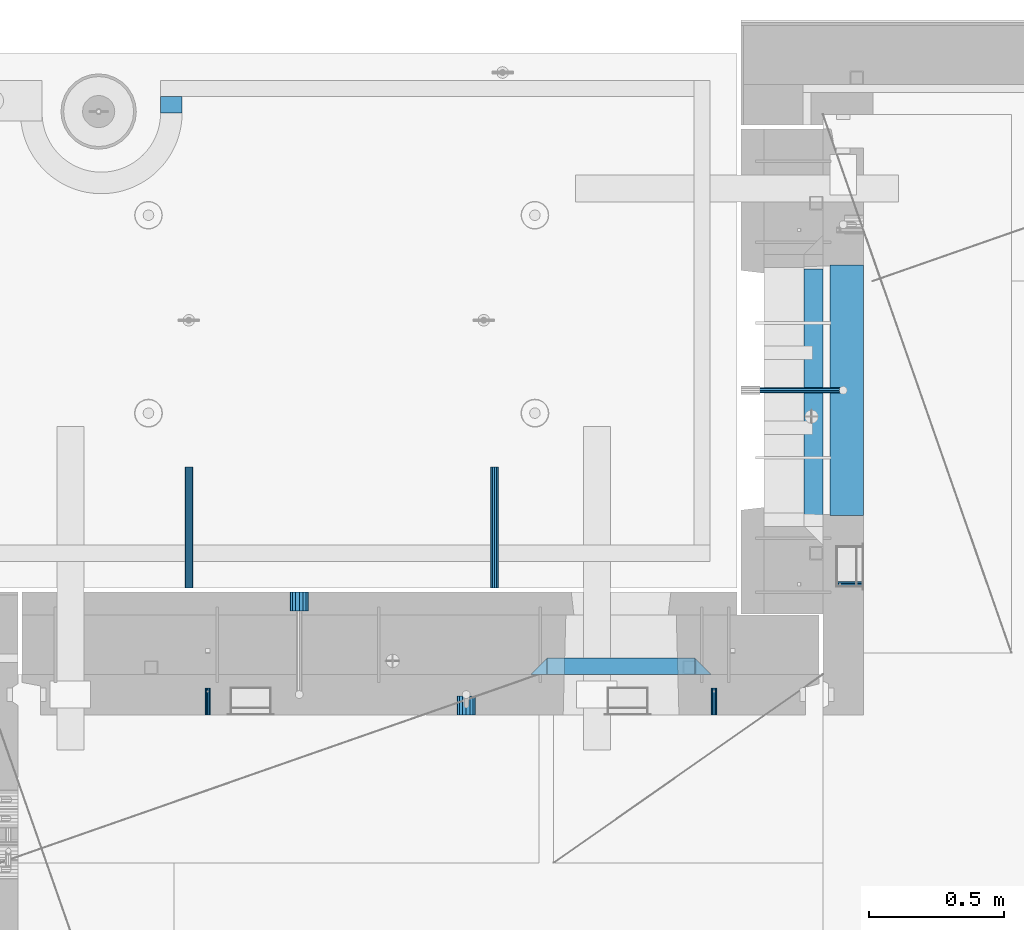
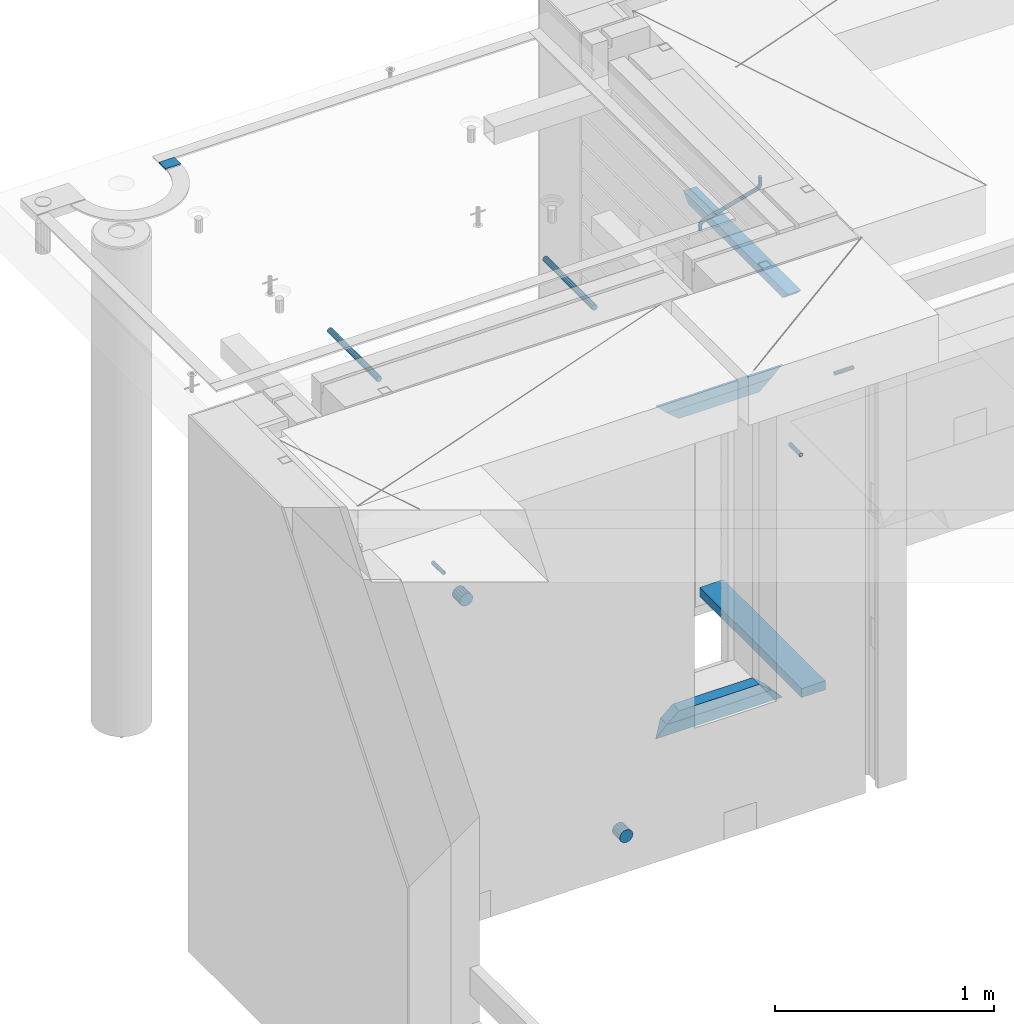
# One storey, part 157 of 350: 15 beams, 8 elements without a shape of their own.
"""IFC2X3 building model written with IfcOpenShell, lengths in millimetres."""

from ifc_helpers import new_model, si_unit, frame, origin_with_axes, place, context, subcontext, project, spatial, faceted_brep, material, type_object, element, aggregate, save


model = new_model("IFC2X3")

# Units and contexts
model_context = context("Model", 3, precision=1e-05, world=origin_with_axes())
body_context = subcontext(model_context, "Body", "Model", "MODEL_VIEW")
ifc_project = project(units=[si_unit("LENGTHUNIT", "METRE", prefix="MILLI"), si_unit("AREAUNIT", "SQUARE_METRE"), si_unit("VOLUMEUNIT", "CUBIC_METRE"), si_unit("MASSUNIT", "GRAM", prefix="KILO"), si_unit("TIMEUNIT", "SECOND"), si_unit("PLANEANGLEUNIT", "RADIAN"), si_unit("SOLIDANGLEUNIT", "STERADIAN"), si_unit("THERMODYNAMICTEMPERATUREUNIT", "DEGREE_CELSIUS"), si_unit("LUMINOUSINTENSITYUNIT", "LUMEN")], contexts=[model_context])

# Site, building, storey
site_placement = place(None, origin_with_axes())
site = spatial("IfcSite", under=ifc_project, at=site_placement, CompositionType="ELEMENT")
building_placement = place(site_placement, origin_with_axes())
building = spatial("IfcBuilding", under=site, at=building_placement, CompositionType="ELEMENT")
storey_placement = place(building_placement, origin_with_axes())
storey = spatial("IfcBuildingStorey", under=building, at=storey_placement, Name="2", CompositionType="ELEMENT", Elevation=0.0)

# Assembly, beam
assembly_1_placement = place(storey_placement, origin_with_axes())
assembly_1 = element("IfcElementAssembly", 1, at=assembly_1_placement, inside=storey, AssemblyPlace="NOTDEFINED", PredefinedType="REINFORCEMENT_UNIT")
ifc_material_1 = material(Name="CONCRETE/C25/30")
beam_type_1 = type_object("IfcBeamType", PredefinedType="NOTDEFINED")
beam_1_placement = place(assembly_1_placement, frame((10955.0, 22139.9998901814, 87080.0), z_axis=(0.0, 0.0, -1.0), x_axis=(0.0, -1.0, 0.0)))
beam_1 = element("IfcBeam", 2, at=beam_1_placement, type_object=beam_type_1, material=ifc_material_1, Name="SK", context=body_context, shape_type="Brep", body=[
    faceted_brep([(100.641025641038, 35.0, 20.6410256410309), (55.0, 35.0, -25.0), (55.0, -35.0, -25.0), (98.8461538461561, -35.0, 18.8461538461561), (966.153464684117, -35.0, 18.8461538461561), (964.358592889246, 35.0, 20.6410256410309), (1009.99961853027, 35.0, -25.0), (1009.99961853027, -35.0, -25.0)], [[[0, 1, 2, 3]], [[0, 3, 4, 5]], [[1, 0, 5, 6]], [[2, 1, 6, 7]], [[3, 2, 7, 4]], [[4, 7, 6, 5]]]),
])

# Assemblies, beams
assembly_2_placement = place(storey_placement, origin_with_axes())
assembly_2 = element("IfcElementAssembly", 3, at=assembly_2_placement, inside=storey, AssemblyPlace="NOTDEFINED", PredefinedType="REINFORCEMENT_UNIT")
assembly_3_placement = place(assembly_2_placement, origin_with_axes())
assembly_3 = element("IfcElementAssembly", 4, at=assembly_3_placement, Name="Steel Assembly", AssemblyPlace="NOTDEFINED", PredefinedType="RIGID_FRAME")
ifc_material_2 = material(Name="STEEL/Steel_Undefined")
beam_type_2 = type_object("IfcBeamType", PredefinedType="NOTDEFINED")
beam_2_placement = place(assembly_3_placement, frame((8704.99903261663, 20429.9951872276, 86755.0), z_axis=(1.0, 0.0, 0.0), x_axis=(0.0, 1.0, 0.0)))
beam_2 = element("IfcBeam", 5, at=beam_2_placement, type_object=beam_type_2, material=ifc_material_2, Name="M16", context=body_context, shape_type="Brep", body=[
    faceted_brep([(0.0, -8.49999999999272, -1.45519152283669e-11), (0.0, -7.36121593215648, 4.24999999998545), (100.000000000262, -7.36121593215648, 4.24999999998545), (100.000000000262, -8.49999999999272, -1.45519152283669e-11), (0.0, -4.24999999998545, 7.36121593216376), (100.000000000262, -4.24999999998545, 7.36121593216376), (0.0, 1.45519152283669e-11, 8.49999999998545), (100.000000000262, 1.45519152283669e-11, 8.49999999998545), (0.0, 4.25000000001455, 7.36121593216376), (100.000000000262, 4.25000000001455, 7.36121593216376), (0.0, 7.36121593217104, 4.24999999998545), (100.000000000262, 7.36121593217104, 4.24999999998545), (0.0, 8.50000000000728, 0.0), (100.000000000262, 8.50000000000728, 0.0), (0.0, 7.36121593217104, -4.25000000001455), (100.000000000262, 7.36121593217104, -4.25000000001455), (0.0, 4.25000000000728, -7.36121593219286), (100.000000000262, 4.25000000000728, -7.36121593219286), (0.0, 7.27595761418343e-12, -8.5), (100.000000000262, 7.27595761418343e-12, -8.5), (0.0, -4.24999999999272, -7.36121593217831), (100.000000000262, -4.24999999999272, -7.36121593217831), (0.0, -7.36121593215648, -4.25), (100.000000000262, -7.36121593215648, -4.25), (0.0, -10.4999999999927, -1.45519152283669e-11), (0.0, -9.09326673972828, -5.25000000001455), (100.000000000262, -9.09326673972828, -5.25000000001455), (100.000000000262, -10.4999999999927, -1.45519152283669e-11), (0.0, -5.24999999998545, -9.09326673974283), (100.000000000262, -5.24999999998545, -9.09326673974283), (0.0, 7.27595761418343e-12, -10.5), (100.000000000262, 7.27595761418343e-12, -10.5), (0.0, 5.25000000001455, -9.09326673975738), (100.000000000262, 5.25000000001455, -9.09326673975738), (0.0, 9.09326673975011, -5.25000000001455), (100.000000000262, 9.09326673975011, -5.25000000001455), (0.0, 10.5000000000073, -1.45519152283669e-11), (100.000000000262, 10.5000000000073, -1.45519152283669e-11), (0.0, 9.09326673975011, 5.25), (100.000000000262, 9.09326673975011, 5.25), (0.0, 5.25000000000728, 9.09326673972828), (100.000000000262, 5.25000000000728, 9.09326673972828), (0.0, 1.45519152283669e-11, 10.4999999999854), (100.000000000262, 1.45519152283669e-11, 10.4999999999854), (0.0, -5.24999999999272, 9.09326673972828), (100.000000000262, -5.24999999999272, 9.09326673972828), (0.0, -9.09326673972828, 5.24999999998545), (100.000000000262, -9.09326673972828, 5.24999999998545)], [[[0, 1, 2, 3]], [[1, 4, 5, 2]], [[4, 6, 7, 5]], [[6, 8, 9, 7]], [[8, 10, 11, 9]], [[10, 12, 13, 11]], [[12, 14, 15, 13]], [[14, 16, 17, 15]], [[16, 18, 19, 17]], [[18, 20, 21, 19]], [[20, 22, 23, 21]], [[22, 0, 3, 23]], [[24, 25, 26, 27]], [[25, 28, 29, 26]], [[28, 30, 31, 29]], [[30, 32, 33, 31]], [[32, 34, 35, 33]], [[34, 36, 37, 35]], [[36, 38, 39, 37]], [[38, 40, 41, 39]], [[40, 42, 43, 41]], [[42, 44, 45, 43]], [[44, 46, 47, 45]], [[46, 24, 27, 47]], [[29, 31, 33, 35, 37, 39, 41, 43, 45, 47, 27, 26], [5, 7, 9, 11, 13, 15, 17, 19, 21, 23, 3, 2]], [[46, 44, 42, 40, 38, 36, 34, 32, 30, 28, 25, 24], [22, 20, 18, 16, 14, 12, 10, 8, 6, 4, 1, 0]]]),
])
aggregate(assembly_3, [beam_2])
assembly_4_placement = place(assembly_2_placement, origin_with_axes())
assembly_4 = element("IfcElementAssembly", 6, at=assembly_4_placement, Name="Steel Assembly", AssemblyPlace="NOTDEFINED", PredefinedType="RIGID_FRAME")
beam_3_placement = place(assembly_4_placement, frame((10584.9990326166, 20429.9951872276, 86755.0), z_axis=(1.0, 0.0, 0.0), x_axis=(0.0, 1.0, 0.0)))
beam_3 = element("IfcBeam", 7, at=beam_3_placement, type_object=beam_type_2, material=ifc_material_2, Name="M16", context=body_context, shape_type="Brep", body=[
    faceted_brep([(0.0, -8.49999999999272, -1.45519152283669e-11), (0.0, -7.36121593215648, 4.24999999998545), (100.000000000262, -7.36121593215648, 4.24999999998545), (100.000000000262, -8.49999999999272, -1.45519152283669e-11), (0.0, -4.24999999998545, 7.36121593216376), (100.000000000262, -4.24999999998545, 7.36121593216376), (0.0, 1.45519152283669e-11, 8.49999999998545), (100.000000000262, 1.45519152283669e-11, 8.49999999998545), (0.0, 4.25000000001455, 7.36121593216376), (100.000000000262, 4.25000000001455, 7.36121593216376), (0.0, 7.36121593217104, 4.24999999998545), (100.000000000262, 7.36121593217104, 4.24999999998545), (0.0, 8.50000000000728, 0.0), (100.000000000262, 8.50000000000728, 0.0), (0.0, 7.36121593217104, -4.25000000001455), (100.000000000262, 7.36121593217104, -4.25000000001455), (0.0, 4.25000000000728, -7.36121593219286), (100.000000000262, 4.25000000000728, -7.36121593219286), (0.0, 7.27595761418343e-12, -8.5), (100.000000000262, 7.27595761418343e-12, -8.5), (0.0, -4.24999999999272, -7.36121593217831), (100.000000000262, -4.24999999999272, -7.36121593217831), (0.0, -7.36121593215648, -4.25), (100.000000000262, -7.36121593215648, -4.25), (0.0, -10.4999999999927, -1.45519152283669e-11), (0.0, -9.09326673972828, -5.25000000001455), (100.000000000262, -9.09326673972828, -5.25000000001455), (100.000000000262, -10.4999999999927, -1.45519152283669e-11), (0.0, -5.24999999998545, -9.09326673974283), (100.000000000262, -5.24999999998545, -9.09326673974283), (0.0, 7.27595761418343e-12, -10.5), (100.000000000262, 7.27595761418343e-12, -10.5), (0.0, 5.25000000001455, -9.09326673975738), (100.000000000262, 5.25000000001455, -9.09326673975738), (0.0, 9.09326673975011, -5.25000000001455), (100.000000000262, 9.09326673975011, -5.25000000001455), (0.0, 10.5000000000073, -1.45519152283669e-11), (100.000000000262, 10.5000000000073, -1.45519152283669e-11), (0.0, 9.09326673975011, 5.25), (100.000000000262, 9.09326673975011, 5.25), (0.0, 5.25000000000728, 9.09326673972828), (100.000000000262, 5.25000000000728, 9.09326673972828), (0.0, 1.45519152283669e-11, 10.4999999999854), (100.000000000262, 1.45519152283669e-11, 10.4999999999854), (0.0, -5.24999999999272, 9.09326673972828), (100.000000000262, -5.24999999999272, 9.09326673972828), (0.0, -9.09326673972828, 5.24999999998545), (100.000000000262, -9.09326673972828, 5.24999999998545)], [[[0, 1, 2, 3]], [[1, 4, 5, 2]], [[4, 6, 7, 5]], [[6, 8, 9, 7]], [[8, 10, 11, 9]], [[10, 12, 13, 11]], [[12, 14, 15, 13]], [[14, 16, 17, 15]], [[16, 18, 19, 17]], [[18, 20, 21, 19]], [[20, 22, 23, 21]], [[22, 0, 3, 23]], [[24, 25, 26, 27]], [[25, 28, 29, 26]], [[28, 30, 31, 29]], [[30, 32, 33, 31]], [[32, 34, 35, 33]], [[34, 36, 37, 35]], [[36, 38, 39, 37]], [[38, 40, 41, 39]], [[40, 42, 43, 41]], [[42, 44, 45, 43]], [[44, 46, 47, 45]], [[46, 24, 27, 47]], [[29, 31, 33, 35, 37, 39, 41, 43, 45, 47, 27, 26], [5, 7, 9, 11, 13, 15, 17, 19, 21, 23, 3, 2]], [[46, 44, 42, 40, 38, 36, 34, 32, 30, 28, 25, 24], [22, 20, 18, 16, 14, 12, 10, 8, 6, 4, 1, 0]]]),
])
aggregate(assembly_4, [beam_3])

# Assembly, beam
assembly_5_placement = place(assembly_1_placement, origin_with_axes())
assembly_5 = element("IfcElementAssembly", 8, at=assembly_5_placement, Name="Steel Assembly", AssemblyPlace="NOTDEFINED", PredefinedType="RIGID_FRAME")
beam_4_placement = place(assembly_5_placement, frame((11140.0, 20914.9954408996, 86755.0), z_axis=(0.0, -1.0, 0.0), x_axis=(-1.0, 3.00000001838171e-08, 0.0)))
beam_4 = element("IfcBeam", 9, at=beam_4_placement, type_object=beam_type_2, material=ifc_material_2, Name="M16", context=body_context, shape_type="Brep", body=[
    faceted_brep([(0.0, -8.49999999999272, -1.45519152283669e-11), (0.0, -7.36121593215648, 4.24999999998545), (100.000000000262, -7.36121593215648, 4.24999999998545), (100.000000000262, -8.49999999999272, -1.45519152283669e-11), (0.0, -4.24999999998545, 7.36121593216376), (100.000000000262, -4.24999999998545, 7.36121593216376), (0.0, 1.45519152283669e-11, 8.49999999998545), (100.000000000262, 1.45519152283669e-11, 8.49999999998545), (0.0, 4.25000000001455, 7.36121593216376), (100.000000000262, 4.25000000001455, 7.36121593216376), (0.0, 7.36121593217104, 4.24999999998545), (100.000000000262, 7.36121593217104, 4.24999999998545), (0.0, 8.50000000000728, 0.0), (100.000000000262, 8.50000000000728, 0.0), (0.0, 7.36121593217104, -4.25000000001455), (100.000000000262, 7.36121593217104, -4.25000000001455), (0.0, 4.25000000000728, -7.36121593219286), (100.000000000262, 4.25000000000728, -7.36121593219286), (0.0, 7.27595761418343e-12, -8.5), (100.000000000262, 7.27595761418343e-12, -8.5), (0.0, -4.24999999999272, -7.36121593217831), (100.000000000262, -4.24999999999272, -7.36121593217831), (0.0, -7.36121593215648, -4.25), (100.000000000262, -7.36121593215648, -4.25), (0.0, -10.4999999999927, -1.45519152283669e-11), (0.0, -9.09326673972828, -5.25000000001455), (100.000000000262, -9.09326673972828, -5.25000000001455), (100.000000000262, -10.4999999999927, -1.45519152283669e-11), (0.0, -5.24999999998545, -9.09326673974283), (100.000000000262, -5.24999999998545, -9.09326673974283), (0.0, 7.27595761418343e-12, -10.5), (100.000000000262, 7.27595761418343e-12, -10.5), (0.0, 5.25000000001455, -9.09326673975738), (100.000000000262, 5.25000000001455, -9.09326673975738), (0.0, 9.09326673975011, -5.25000000001455), (100.000000000262, 9.09326673975011, -5.25000000001455), (0.0, 10.5000000000073, -1.45519152283669e-11), (100.000000000262, 10.5000000000073, -1.45519152283669e-11), (0.0, 9.09326673975011, 5.25), (100.000000000262, 9.09326673975011, 5.25), (0.0, 5.25000000000728, 9.09326673972828), (100.000000000262, 5.25000000000728, 9.09326673972828), (0.0, 1.45519152283669e-11, 10.4999999999854), (100.000000000262, 1.45519152283669e-11, 10.4999999999854), (0.0, -5.24999999999272, 9.09326673972828), (100.000000000262, -5.24999999999272, 9.09326673972828), (0.0, -9.09326673972828, 5.24999999998545), (100.000000000262, -9.09326673972828, 5.24999999998545)], [[[0, 1, 2, 3]], [[1, 4, 5, 2]], [[4, 6, 7, 5]], [[6, 8, 9, 7]], [[8, 10, 11, 9]], [[10, 12, 13, 11]], [[12, 14, 15, 13]], [[14, 16, 17, 15]], [[16, 18, 19, 17]], [[18, 20, 21, 19]], [[20, 22, 23, 21]], [[22, 0, 3, 23]], [[24, 25, 26, 27]], [[25, 28, 29, 26]], [[28, 30, 31, 29]], [[30, 32, 33, 31]], [[32, 34, 35, 33]], [[34, 36, 37, 35]], [[36, 38, 39, 37]], [[38, 40, 41, 39]], [[40, 42, 43, 41]], [[42, 44, 45, 43]], [[44, 46, 47, 45]], [[46, 24, 27, 47]], [[29, 31, 33, 35, 37, 39, 41, 43, 45, 47, 27, 26], [5, 7, 9, 11, 13, 15, 17, 19, 21, 23, 3, 2]], [[46, 44, 42, 40, 38, 36, 34, 32, 30, 28, 25, 24], [22, 20, 18, 16, 14, 12, 10, 8, 6, 4, 1, 0]]]),
])
aggregate(assembly_5, [beam_4])

# Beam
ifc_material_3 = material()
beam_type_3 = type_object("IfcBeamType", Name="D20", PredefinedType="NOTDEFINED")
beam_5_placement = place(assembly_1_placement, frame((10747.93, 21634.9982799665, 87220.28), z_axis=(0.999209485784166, 0.00020572799995638, -0.0397537569914116), x_axis=(0.0397537569984931, -6.39999925638531e-08, 0.999209506962629)))
beam_5 = element("IfcBeam", 10, at=beam_5_placement, type_object=beam_type_3, material=ifc_material_3, Name="JM20", ObjectType="D20", context=body_context, shape_type="Brep", body=[
    faceted_brep([(0.0, -10.0, 0.0), (-4.19531716033816e-08, -7.07106781186667, -7.07106781187031), (26.3851730625611, -7.07106780271351, -7.07106779974674), (26.3851730660535, -9.99999999077045, 1.18243406177498e-08), (0.0, 0.0, -10.0), (26.3851730589668, 9.14587872102857e-09, -9.99999998788189), (4.196772351861e-08, 7.07106781186303, -7.07106781186667), (26.3851730576571, 7.07106782101255, -7.0710677997472), (0.0, 10.0, 0.0), (26.3851730593888, 10.0000000091495, 1.21176526590716e-08), (4.196772351861e-08, 7.07106781185939, 7.07106781185939), (26.3851730631723, 7.07106782101619, 7.07106782398387), (0.0, 0.0, 10.0), (26.3851730667375, 9.15315467864275e-09, 10.0000000121181), (-4.19531716033816e-08, -7.07106781187031, 7.07106781185939), (26.3851730680617, -7.07106780271351, 7.07106782398296), (38.6387990555377, 0.00053833780111745, -7.38336449283906), (37.4430586178205, -7.07058200552274, -4.70977034770021), (34.5550974405633, -9.99964106806146, 1.74460312923975), (31.6666440137633, -7.07083577596131, 8.19887149183023), (30.4697151806322, 0.000179452214069897, 10.8722118684241), (31.6654556183639, 7.07129979554884, 8.19861772327886), (34.5534167956066, 10.0003588580803, 1.74424424634026), (37.4418702223775, 7.07155356597286, -4.71002411625204), (46.5698109210789, 7.07292605872499, 1.96124086770624), (48.7548734831362, 0.00205940803425619, 0.0100898832683924), (41.2967727296491, 10.0013728005906, 6.67270684289633), (36.0246331664675, 7.07195524891722, 11.3845749391899), (33.8417400848848, 0.000686475628754124, 13.3366967298962), (36.0268026468402, -7.07018017507653, 11.385545745416), (41.2998408382991, -9.99862691692761, 6.67407977023777), (46.5719804015243, -7.06920936526149, 1.96221167398289), (52.1766955363273, 7.07494587836845, 11.77897587077), (54.9687243336812, 0.00429788071051007, 10.8906314292522), (45.4389138642146, 10.0028649622, 13.9256551011317), (38.7022804405424, 7.07291984242329, 16.0731735411446), (35.9130237601494, 0.00143263318750542, 16.9635440140905), (38.7050525575032, -7.06921536447044, 16.0751995724927), (45.4428342298197, -9.99713444846202, 13.9285203429881), (52.1794676532882, -7.06718932852891, 11.7810019021831), (142.166420299589, -7.00909836739083, 294.143799597011), (135.429786872017, -9.93904348683645, 296.291318034092), (144.955676979953, 0.0623888418631395, 293.253429124143), (142.163648182657, 7.13303683951744, 294.141773565681), (135.425866510661, 10.0609559233271, 296.288452795829), (128.689233087061, 7.13101080351771, 298.435971235634), (125.899976406712, 0.0595235942673753, 299.326341708503), (128.692005203993, -7.01112440339057, 298.437997266966), (147.068569920637, 0.0631443010061048, 296.926548661886), (144.897857494318, -7.00812174957537, 298.892215917644), (139.655137467547, -9.93753272500544, 303.636800386314), (134.411524128242, -7.00907940566321, 308.380988833921), (132.238655054738, 0.0617899707685865, 310.345700010335), (134.409367481101, 7.13305602133914, 308.38003275464), (139.652087507944, 10.0624669967765, 303.63544828606), (144.895700847192, 7.13401367743427, 298.891259838389), (149.349355837621, 7.13466950711154, 302.082919188319), (150.512901837996, 0.0636515012993186, 299.394888529177), (146.541460642286, 10.0634815017911, 308.572636332), (143.734043175544, 7.13442914049301, 315.062451673432), (142.571650514263, 0.0633115715718304, 317.750719402909), (143.735196514695, -7.0077064342513, 315.062688743805), (146.543091710148, -9.93651842893087, 308.572971600169), (149.350509176773, -7.0074660676255, 302.083156258706), (154.724909358454, 7.13488656737172, 303.143653317829), (154.670204234542, 0.063819369621342, 300.215230568659), (154.856921558763, 10.0638172729959, 310.213489346082), (154.988909878753, 7.13488360238989, 317.283324591871), (155.043557350815, 0.0638151764978829, 320.211745451903), (154.988852227005, -7.00725202125614, 317.28332270274), (154.856840031658, -9.93618272723688, 310.213486674455), (154.724851706691, -7.00724905626703, 303.143651428684), (199.544700311235, -7.00743165723543, 302.30682413155), (199.676688632229, -9.93636532781238, 309.37665937721), (199.490052838737, 0.0636367686238373, 299.378403271518), (199.544757962984, 7.13470396637786, 302.306826020583), (199.676770164122, 10.0636346720203, 309.376662048705), (199.808758485131, 7.13470100144696, 316.446497294365), (199.863405957614, 0.0636325755804137, 319.374918154397), (199.808700833368, -7.00743462216269, 316.446495405334)], [[[0, 1, 2, 3]], [[1, 4, 5, 2]], [[4, 6, 7, 5]], [[6, 8, 9, 7]], [[8, 10, 11, 9]], [[10, 12, 13, 11]], [[12, 14, 15, 13]], [[14, 0, 3, 15]], [[14, 12, 10, 8, 6, 4, 1, 0]], [[2, 5, 16, 17]], [[3, 2, 17, 18]], [[15, 3, 18, 19]], [[13, 15, 19, 20]], [[11, 13, 20, 21]], [[9, 11, 21, 22]], [[7, 9, 22, 23]], [[5, 7, 23, 16]], [[23, 24, 25, 16]], [[22, 26, 24, 23]], [[21, 27, 26, 22]], [[20, 28, 27, 21]], [[19, 29, 28, 20]], [[18, 30, 29, 19]], [[17, 31, 30, 18]], [[16, 25, 31, 17]], [[24, 32, 33, 25]], [[26, 34, 32, 24]], [[27, 35, 34, 26]], [[28, 36, 35, 27]], [[29, 37, 36, 28]], [[30, 38, 37, 29]], [[31, 39, 38, 30]], [[25, 33, 39, 31]], [[38, 39, 40, 41]], [[39, 33, 42, 40]], [[33, 32, 43, 42]], [[32, 34, 44, 43]], [[34, 35, 45, 44]], [[35, 36, 46, 45]], [[36, 37, 47, 46]], [[37, 38, 41, 47]], [[40, 42, 48, 49]], [[41, 40, 49, 50]], [[47, 41, 50, 51]], [[46, 47, 51, 52]], [[45, 46, 52, 53]], [[44, 45, 53, 54]], [[43, 44, 54, 55]], [[42, 43, 55, 48]], [[55, 56, 57, 48]], [[54, 58, 56, 55]], [[53, 59, 58, 54]], [[52, 60, 59, 53]], [[51, 61, 60, 52]], [[50, 62, 61, 51]], [[49, 63, 62, 50]], [[48, 57, 63, 49]], [[56, 64, 65, 57]], [[58, 66, 64, 56]], [[59, 67, 66, 58]], [[60, 68, 67, 59]], [[61, 69, 68, 60]], [[62, 70, 69, 61]], [[63, 71, 70, 62]], [[57, 65, 71, 63]], [[70, 71, 72, 73]], [[71, 65, 74, 72]], [[65, 64, 75, 74]], [[64, 66, 76, 75]], [[66, 67, 77, 76]], [[67, 68, 78, 77]], [[68, 69, 79, 78]], [[69, 70, 73, 79]], [[74, 75, 76, 77, 78, 79, 73, 72]]]),
])

beam_type_4 = type_object("IfcBeamType", Name="D70", PredefinedType="NOTDEFINED")
beam_6_placement = place(assembly_2_placement, frame((9665.00172002957, 20429.9951872276, 84955.0), z_axis=(0.0, 0.0, 1.0), x_axis=(0.0, 1.0, 0.0)))
beam_6 = element("IfcBeam", 11, at=beam_6_placement, type_object=beam_type_4, material=ifc_material_3, ObjectType="D70", context=body_context, shape_type="Brep", body=[
    faceted_brep([(0.0, -35.0, 0.0), (0.0, -32.3357836378964, -13.3939201327739), (70.0, -32.3357836378964, -13.3939201327739), (70.0, -35.0, 0.0), (0.0, -24.7487373415279, -24.7487373415352), (70.0, -24.7487373415279, -24.7487373415352), (0.0, -13.3939201327776, -32.3357836379), (70.0, -13.3939201327776, -32.3357836379), (0.0, 0.0, -35.0), (70.0, 0.0, -35.0), (0.0, 13.3939201327776, -32.3357836379), (70.0, 13.3939201327776, -32.3357836379), (0.0, 24.7487373415279, -24.7487373415352), (70.0, 24.7487373415279, -24.7487373415352), (0.0, 32.3357836378964, -13.3939201327739), (70.0, 32.3357836378964, -13.3939201327739), (0.0, 35.0, 0.0), (70.0, 35.0, 0.0), (0.0, 32.3357836378964, 13.3939201327739), (70.0, 32.3357836378964, 13.3939201327739), (0.0, 24.7487373415279, 24.7487373415352), (70.0, 24.7487373415279, 24.7487373415352), (0.0, 13.3939201327776, 32.3357836379), (70.0, 13.3939201327776, 32.3357836379), (0.0, 0.0, 35.0), (70.0, 0.0, 35.0), (0.0, -13.3939201327776, 32.3357836379), (70.0, -13.3939201327776, 32.3357836379), (0.0, -24.7487373415279, 24.7487373415352), (70.0, -24.7487373415279, 24.7487373415352), (0.0, -32.3357836378964, 13.3939201327739), (70.0, -32.3357836378964, 13.3939201327739)], [[[0, 1, 2, 3]], [[1, 4, 5, 2]], [[4, 6, 7, 5]], [[6, 8, 9, 7]], [[8, 10, 11, 9]], [[10, 12, 13, 11]], [[12, 14, 15, 13]], [[14, 16, 17, 15]], [[16, 18, 19, 17]], [[18, 20, 21, 19]], [[20, 22, 23, 21]], [[22, 24, 25, 23]], [[24, 26, 27, 25]], [[26, 28, 29, 27]], [[28, 30, 31, 29]], [[30, 0, 3, 31]], [[5, 7, 9, 11, 13, 15, 17, 19, 21, 23, 25, 27, 29, 31, 3, 2]], [[30, 28, 26, 24, 22, 20, 18, 16, 14, 12, 10, 8, 6, 4, 1, 0]]]),
])

beam_7_placement = place(assembly_2_placement, frame((9044.99633327303, 20884.9951872276, 86255.0), z_axis=(0.0, 0.0, 1.0), x_axis=(0.0, -1.0, 0.0)))
beam_7 = element("IfcBeam", 12, at=beam_7_placement, type_object=beam_type_4, material=ifc_material_3, ObjectType="D70", context=body_context, shape_type="Brep", body=[
    faceted_brep([(0.0, -35.0, 0.0), (0.0, -32.3357836378964, -13.3939201327739), (70.0, -32.3357836378964, -13.3939201327739), (70.0, -35.0, 0.0), (0.0, -24.7487373415279, -24.7487373415352), (70.0, -24.7487373415279, -24.7487373415352), (0.0, -13.3939201327776, -32.3357836379), (70.0, -13.3939201327776, -32.3357836379), (0.0, 0.0, -35.0), (70.0, 0.0, -35.0), (0.0, 13.3939201327776, -32.3357836379), (70.0, 13.3939201327776, -32.3357836379), (0.0, 24.7487373415279, -24.7487373415352), (70.0, 24.7487373415279, -24.7487373415352), (0.0, 32.3357836378964, -13.3939201327739), (70.0, 32.3357836378964, -13.3939201327739), (0.0, 35.0, 0.0), (70.0, 35.0, 0.0), (0.0, 32.3357836378964, 13.3939201327739), (70.0, 32.3357836378964, 13.3939201327739), (0.0, 24.7487373415279, 24.7487373415352), (70.0, 24.7487373415279, 24.7487373415352), (0.0, 13.3939201327776, 32.3357836379), (70.0, 13.3939201327776, 32.3357836379), (0.0, 0.0, 35.0), (70.0, 0.0, 35.0), (0.0, -13.3939201327776, 32.3357836379), (70.0, -13.3939201327776, 32.3357836379), (0.0, -24.7487373415279, 24.7487373415352), (70.0, -24.7487373415279, 24.7487373415352), (0.0, -32.3357836378964, 13.3939201327739), (70.0, -32.3357836378964, 13.3939201327739)], [[[0, 1, 2, 3]], [[1, 4, 5, 2]], [[4, 6, 7, 5]], [[6, 8, 9, 7]], [[8, 10, 11, 9]], [[10, 12, 13, 11]], [[12, 14, 15, 13]], [[14, 16, 17, 15]], [[16, 18, 19, 17]], [[18, 20, 21, 19]], [[20, 22, 23, 21]], [[22, 24, 25, 23]], [[24, 26, 27, 25]], [[26, 28, 29, 27]], [[28, 30, 31, 29]], [[30, 0, 3, 31]], [[5, 7, 9, 11, 13, 15, 17, 19, 21, 23, 25, 27, 29, 31, 3, 2]], [[30, 28, 26, 24, 22, 20, 18, 16, 14, 12, 10, 8, 6, 4, 1, 0]]]),
])

ifc_material_4 = material(Name="TIMBER/PUU")
beam_type_5 = type_object("IfcBeamType", PredefinedType="NOTDEFINED")
beam_8_placement = place(assembly_1_placement, frame((11077.5, 21169.9999618525, 84830.0), z_axis=(0.0, 0.0, 1.0), x_axis=(0.0, 1.0, 0.0)))
beam_8 = element("IfcBeam", 13, at=beam_8_placement, type_object=beam_type_5, material=ifc_material_4, context=body_context, shape_type="Brep", body=[
    faceted_brep([(0.0, 62.5, -25.0), (0.0, 62.5, 25.0), (930.0, 62.5, 25.0), (930.0, 62.5, -25.0), (0.0, -62.5, 25.0), (930.0, -62.5, 25.0), (0.0, -62.5, -25.0), (930.0, -62.5, -25.0)], [[[0, 1, 2, 3]], [[1, 4, 5, 2]], [[4, 6, 7, 5]], [[6, 0, 3, 7]], [[5, 7, 3, 2]], [[6, 4, 1, 0]]]),
])

aggregate(assembly_1, [beam_5, assembly_5, beam_8, beam_1])

# Assemblies, beams
assembly_6_placement = place(storey_placement, origin_with_axes())
assembly_6 = element("IfcElementAssembly", 14, at=assembly_6_placement, inside=storey, AssemblyPlace="NOTDEFINED", PredefinedType="REINFORCEMENT_UNIT")
assembly_7_placement = place(assembly_6_placement, origin_with_axes())
assembly_7 = element("IfcElementAssembly", 15, at=assembly_7_placement, Name="Steel Assembly", AssemblyPlace="NOTDEFINED", PredefinedType="RIGID_FRAME")
ifc_material_5 = material(Name="STEEL/S235JR")
beam_type_6 = type_object("IfcBeamType", Name="D30", PredefinedType="NOTDEFINED")
beam_9_placement = place(assembly_7_placement, frame((8634.99985675633, 20900.0253394533, 87575.0), z_axis=(0.0, 0.0, 1.0), x_axis=(0.0, 1.0, 0.0)))
beam_9 = element("IfcBeam", 16, at=beam_9_placement, type_object=beam_type_6, material=ifc_material_5, Name="Rd30", ObjectType="D30", context=body_context, shape_type="Brep", body=[
    faceted_brep([(0.0, -15.0, 0.0), (0.0, -12.9903810567666, -7.5), (450.0, -12.9903810567666, -7.5), (450.0, -15.0, 0.0), (0.0, -7.5, -12.9903810567666), (450.0, -7.5, -12.990381056763), (0.0, 0.0, -15.0), (450.0, 0.0, -15.0), (0.0, 7.5, -12.9903810567666), (450.0, 7.5, -12.990381056763), (0.0, 12.9903810567666, -7.5), (450.0, 12.9903810567666, -7.5), (0.0, 15.0, 0.0), (450.0, 15.0, 0.0), (0.0, 12.9903810567666, 7.5), (450.0, 12.9903810567666, 7.5), (0.0, 7.5, 12.9903810567666), (450.0, 7.5, 12.990381056763), (0.0, 0.0, 15.0), (450.0, 0.0, 15.0), (0.0, -7.5, 12.9903810567666), (450.0, -7.5, 12.990381056763), (0.0, -12.9903810567666, 7.5), (450.0, -12.9903810567666, 7.5)], [[[0, 1, 2, 3]], [[1, 4, 5, 2]], [[4, 6, 7, 5]], [[6, 8, 9, 7]], [[8, 10, 11, 9]], [[10, 12, 13, 11]], [[12, 14, 15, 13]], [[14, 16, 17, 15]], [[16, 18, 19, 17]], [[18, 20, 21, 19]], [[20, 22, 23, 21]], [[22, 0, 3, 23]], [[5, 7, 9, 11, 13, 15, 17, 19, 21, 23, 3, 2]], [[22, 20, 18, 16, 14, 12, 10, 8, 6, 4, 1, 0]]]),
])
aggregate(assembly_7, [beam_9])
assembly_8_placement = place(assembly_6_placement, origin_with_axes())
assembly_8 = element("IfcElementAssembly", 17, at=assembly_8_placement, Name="Steel Assembly", AssemblyPlace="NOTDEFINED", PredefinedType="RIGID_FRAME")
beam_10_placement = place(assembly_8_placement, frame((9769.99985700661, 20900.0152136098, 87575.0), z_axis=(0.0, 0.0, 1.0), x_axis=(0.0, 1.0, 0.0)))
beam_10 = element("IfcBeam", 18, at=beam_10_placement, type_object=beam_type_6, material=ifc_material_5, Name="Rd30", ObjectType="D30", context=body_context, shape_type="Brep", body=[
    faceted_brep([(0.0, -15.0, 0.0), (0.0, -12.9903810567666, -7.5), (450.0, -12.9903810567666, -7.5), (450.0, -15.0, 0.0), (0.0, -7.5, -12.9903810567666), (450.0, -7.5, -12.990381056763), (0.0, 0.0, -15.0), (450.0, 0.0, -15.0), (0.0, 7.5, -12.9903810567666), (450.0, 7.5, -12.990381056763), (0.0, 12.9903810567666, -7.5), (450.0, 12.9903810567666, -7.5), (0.0, 15.0, 0.0), (450.0, 15.0, 0.0), (0.0, 12.9903810567666, 7.5), (450.0, 12.9903810567666, 7.5), (0.0, 7.5, 12.9903810567666), (450.0, 7.5, 12.990381056763), (0.0, 0.0, 15.0), (450.0, 0.0, 15.0), (0.0, -7.5, 12.9903810567666), (450.0, -7.5, 12.990381056763), (0.0, -12.9903810567666, 7.5), (450.0, -12.9903810567666, 7.5)], [[[0, 1, 2, 3]], [[1, 4, 5, 2]], [[4, 6, 7, 5]], [[6, 8, 9, 7]], [[8, 10, 11, 9]], [[10, 12, 13, 11]], [[12, 14, 15, 13]], [[14, 16, 17, 15]], [[16, 18, 19, 17]], [[18, 20, 21, 19]], [[20, 22, 23, 21]], [[22, 0, 3, 23]], [[5, 7, 9, 11, 13, 15, 17, 19, 21, 23, 3, 2]], [[22, 20, 18, 16, 14, 12, 10, 8, 6, 4, 1, 0]]]),
])
aggregate(assembly_8, [beam_10])

# Beam
beam_type_7 = type_object("IfcBeamType", PredefinedType="NOTDEFINED")
beam_11_placement = place(assembly_2_placement, frame((10575.0002360344, 20609.9951872276, 87145.0), z_axis=(0.0, 0.0, -1.0), x_axis=(-1.0, 3.00000001838171e-08, 0.0)))
beam_11 = element("IfcBeam", 19, at=beam_11_placement, type_object=beam_type_7, material=ifc_material_1, Name="SK", context=body_context, shape_type="Brep", body=[
    faceted_brep([(60.0000000000073, 30.0, 30.0), (0.0, -30.0, -30.0), (60.0000000000073, -30.0, 30.0), (610.001525878895, 30.0, 30.0), (670.001525878906, -30.0, -30.0), (610.001525878895, -30.0, 30.0)], [[[0, 1, 2]], [[1, 0, 3, 4]], [[2, 1, 4, 5]], [[0, 2, 5, 3]], [[5, 4, 3]]]),
])

beam_12_placement = place(assembly_2_placement, frame((10515.0002360344, 20609.9951872276, 87085.0), z_axis=(0.0, 0.0, -1.0), x_axis=(-1.0, 3.00000001838171e-08, 0.0)))
beam_12 = element("IfcBeam", 20, at=beam_12_placement, type_object=beam_type_7, material=ifc_material_1, Name="SK", context=body_context, shape_type="Brep", body=[
    faceted_brep([(0.0, -30.0, -30.0), (64.0555799329595, -30.0, 24.9047827876493), (65.6772015545812, 30.0, 26.2947441772849), (0.0, 30.0, -30.0), (64.0555799329595, -30.0, 24.0540540540533), (65.6772015545812, 30.0, 25.6756756756804), (485.947471824853, -30.0, 24.0540540540533), (484.325850203231, 30.0, 25.6756756756804), (484.325850203231, 30.0, 26.293436281092), (550.001525878906, 30.0, -30.0), (550.001525878906, -30.0, -30.0), (485.947471824853, -30.0, 24.9034748914273)], [[[0, 1, 2, 3]], [[4, 5, 2, 1]], [[6, 7, 5, 4]], [[3, 2, 5, 7, 8, 9]], [[0, 3, 9, 10]], [[6, 4, 1, 0, 10, 11]], [[7, 6, 11, 8]], [[8, 11, 10, 9]]]),
])

beam_13_placement = place(assembly_2_placement, frame((9904.99871015549, 20609.9951872276, 85350.0), z_axis=(0.0, 0.0, 1.0), x_axis=(1.0, 0.0, 0.0)))
beam_13 = element("IfcBeam", 21, at=beam_13_placement, type_object=beam_type_7, material=ifc_material_1, Name="SK", context=body_context, shape_type="Brep", body=[
    faceted_brep([(610.001525878895, -30.0, 30.0), (670.001525878906, -30.0, -30.0), (610.001525878895, 30.0, 30.0), (60.0000000000073, 30.0, 30.0), (60.0000000000073, -30.0, 30.0), (0.0, -30.0, -30.0)], [[[0, 1, 2]], [[3, 4, 0, 2]], [[4, 5, 1, 0]], [[5, 3, 2, 1]], [[3, 5, 4]]]),
])

beam_14_placement = place(assembly_2_placement, frame((9964.99871015549, 20609.9951872276, 85410.0), z_axis=(0.0, 0.0, 1.0), x_axis=(1.0, 0.0, 0.0)))
beam_14 = element("IfcBeam", 22, at=beam_14_placement, type_object=beam_type_7, material=ifc_material_1, Name="SK", context=body_context, shape_type="Brep", body=[
    faceted_brep([(550.001525878906, -30.0, -30.0), (550.001525878906, 30.0, -30.0), (484.324324324325, 30.0, 26.2947441772849), (485.945945945947, -30.0, 24.9047827876348), (484.324324324325, 30.0, 25.6756756756804), (485.945945945947, -30.0, 24.0540540540533), (65.6756756756768, 30.0, 25.6756756756804), (64.0540540540533, -30.0, 24.0540540540533), (65.6756756756768, 30.0, 26.293436281092), (64.0540540540533, -30.0, 24.9034748914419), (0.0, -30.0, -30.0), (0.0, 30.0, -30.0)], [[[0, 1, 2, 3]], [[4, 5, 3, 2]], [[5, 4, 6, 7]], [[7, 6, 8, 9]], [[0, 3, 5, 7, 9, 10]], [[10, 11, 1, 0]], [[6, 4, 2, 1, 11, 8]], [[10, 9, 8, 11]]]),
])

aggregate(assembly_2, [assembly_3, assembly_4, beam_6, beam_7, beam_11, beam_12, beam_13, beam_14])

ifc_material_6 = material(Name="CONCRETE/Concrete_Undefined")
beam_type_8 = type_object("IfcBeamType", PredefinedType="NOTDEFINED")
beam_15_placement = place(assembly_6_placement, frame((8570.00544375128, 22665.0534145719, 87707.3590237257), z_axis=(1.00999999609277e-07, -0.00299573299934615, 0.999995512781826), x_axis=(-0.000187248000059734, 0.999995495250841, 0.0029957330006511)))
beam_15 = element("IfcBeam", 23, at=beam_15_placement, type_object=beam_type_8, material=ifc_material_6, context=body_context, shape_type="Brep", body=[
    faceted_brep([(1.34605215862393e-10, 40.0, -5.0), (-1.20053300634027e-10, 39.9999999999982, 4.99999999998545), (60.1825564420724, 39.9999999999982, 5.0), (60.182556442418, 40.0, -5.0), (-1.23691279441118e-10, -40.0000000000018, 4.9999999999709), (60.1825564420724, -40.0, 5.0), (1.30967237055302e-10, -40.0, -5.00000000001455), (60.182556442418, -39.9999999999982, -5.0)], [[[0, 1, 2, 3]], [[1, 4, 5, 2]], [[4, 6, 7, 5]], [[6, 0, 3, 7]], [[5, 7, 3, 2]], [[6, 4, 1, 0]]]),
])

aggregate(assembly_6, [assembly_7, assembly_8, beam_15])

save(model, "model.ifc")
